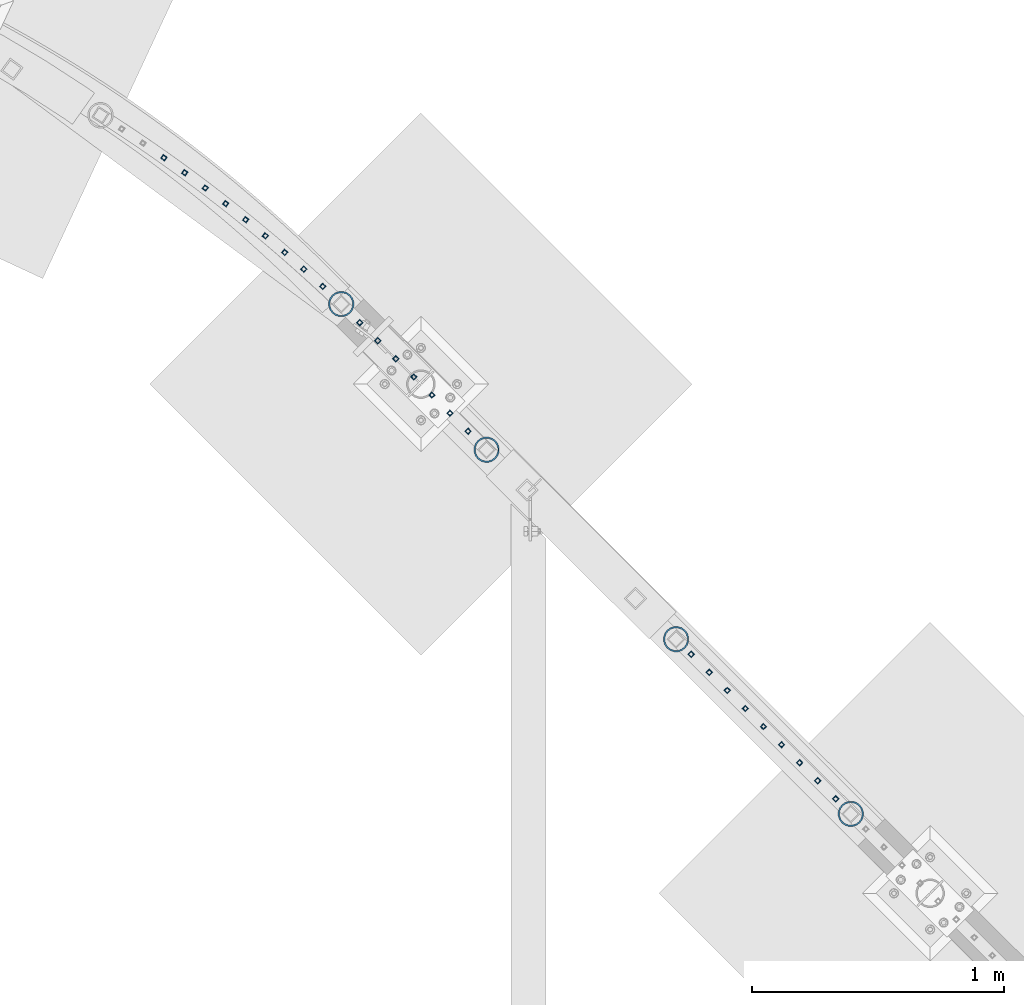
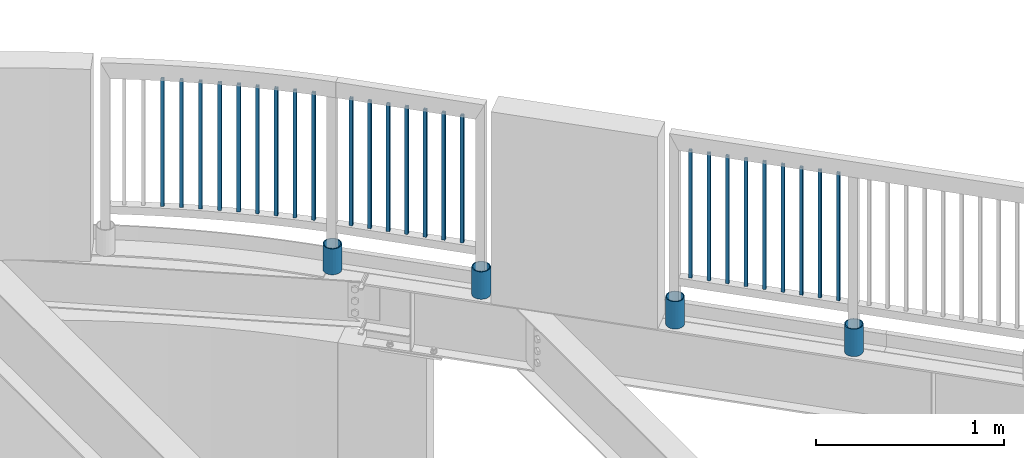
# One storey, part 252 of 975: 29 columns.
"""IFC2X3 building model written with IfcOpenShell, lengths in millimetres."""

import ifcopenshell
import ifcopenshell.guid

model = None  # the IFC model being written
_history = None  # IfcOwnerHistory: only IFC2X3 demands one
_inside = {}  # id of a spatial element -> (the spatial element, [elements in it])
_under = {}  # id of a project, library or spatial element -> (it, [spatial elements below it])
_declared = {}  # id of a project -> (the project, [libraries it declares])
_typed = {}  # id of a type object -> (the type object, [elements of that type])
_made_of = {}  # id of a material, layer set ... -> (it, [elements and type objects made of it])


def new_model(schema):
    """Start an empty IFC model of exactly this schema.

    Asked for "IFC4X3", IfcOpenShell would pick the latest addendum, in which some entities
    have other attributes; the version numbers below select the first issue.
    IFC2X3 requires an IfcOwnerHistory on every rooted entity: one is made here for all.
    """
    global model, _history
    if schema == "IFC4X3":
        model = ifcopenshell.file(schema_version=(4, 3, 0, 0))
    else:
        model = ifcopenshell.file(schema=schema)
    _inside.clear()
    _under.clear()
    _declared.clear()
    _typed.clear()
    _made_of.clear()
    _history = None
    if model.schema == "IFC2X3":
        org = make("IfcOrganization", Name="unknown")
        user = make(
            "IfcPersonAndOrganization",
            ThePerson=make("IfcPerson", FamilyName="unknown"),
            TheOrganization=org,
        )
        app = make(
            "IfcApplication",
            ApplicationDeveloper=org,
            Version="unknown",
            ApplicationFullName="unknown",
            ApplicationIdentifier="unknown",
        )
        _history = make(
            "IfcOwnerHistory",
            OwningUser=user,
            OwningApplication=app,
            ChangeAction="ADDED",
            CreationDate=0,
        )
    return model


def make(cls, **values):
    """One entity of the class cls with the attributes given. An attribute that is None is left unset."""
    return model.create_entity(
        cls, **{name: value for name, value in values.items() if value is not None}
    )


def rooted(cls, **values):
    """An entity with a GlobalId (a new one), such as an element, a storey or a relation."""
    return make(cls, GlobalId=ifcopenshell.guid.new(), OwnerHistory=_history, **values)


def si_unit(unit_type, name, prefix=None):
    """IfcSIUnit, for example si_unit("LENGTHUNIT", "METRE", prefix="MILLI")."""
    return make("IfcSIUnit", UnitType=unit_type, Prefix=prefix, Name=name)


def assignment(units):
    """IfcUnitAssignment: the units of a project."""
    return None if units is None else make("IfcUnitAssignment", Units=units)


def point(xyz):
    """IfcCartesianPoint."""
    return None if xyz is None else make("IfcCartesianPoint", Coordinates=xyz)


def direction(xyz):
    """IfcDirection."""
    return None if xyz is None else make("IfcDirection", DirectionRatios=xyz)


def frame(location, z_axis=None, x_axis=None):
    """IfcAxis2Placement3D, a coordinate frame: its origin and axes. An axis left out is left unset."""
    return make(
        "IfcAxis2Placement3D",
        Location=point(location),
        Axis=direction(z_axis),
        RefDirection=direction(x_axis),
    )


def origin_with_axes():
    """The frame at (0, 0, 0) with the z axis (0, 0, 1) and the x axis (1, 0, 0) written out."""
    return frame((0.0, 0.0, 0.0), z_axis=(0.0, 0.0, 1.0), x_axis=(1.0, 0.0, 0.0))


def place(relative_to, where):
    """IfcLocalPlacement: puts the frame where relative to a parent placement (None: the world)."""
    return make(
        "IfcLocalPlacement", PlacementRelTo=relative_to, RelativePlacement=where
    )


def context(
    kind, dimensions, precision=None, world=None, true_north=None, identifier=None
):
    """IfcGeometricRepresentationContext, for example the 3D "Model" context."""
    return make(
        "IfcGeometricRepresentationContext",
        ContextIdentifier=identifier,
        ContextType=kind,
        CoordinateSpaceDimension=dimensions,
        Precision=precision,
        WorldCoordinateSystem=world,
        TrueNorth=true_north,
    )


def subcontext(parent, identifier, kind, view, scale=None):
    """IfcGeometricRepresentationSubContext, for example "Body" below "Model"."""
    return make(
        "IfcGeometricRepresentationSubContext",
        ContextIdentifier=identifier,
        ContextType=kind,
        ParentContext=parent,
        TargetScale=scale,
        TargetView=view,
    )


def project(units=None, contexts=None):
    """IfcProject with its units and contexts."""
    return rooted(
        "IfcProject",
        Name="project",
        RepresentationContexts=contexts,
        UnitsInContext=assignment(units),
    )


def spatial(cls, under=None, at=None, **own):
    """A site, building, storey or space (cls), placed at a placement, below another one or the project."""
    s = rooted(cls, ObjectPlacement=at, **own)
    if under is not None:
        _under.setdefault(under.id(), (under, []))[1].append(s)
    return s


def faces_of(points, faces, orient=None, outer=None):
    """IfcFace entities. A face is a list of loops; a loop is a list of indices into points, from 0.

    orient and outer hold one flag for each loop. By default every Orientation is true, the
    first loop of a face is its IfcFaceOuterBound and the others are IfcFaceBound.
    """
    made = []
    for i, loops in enumerate(faces):
        bounds = []
        for j, loop in enumerate(loops):
            is_outer = j == 0 if outer is None else outer[i][j]
            bounds.append(
                make(
                    "IfcFaceOuterBound" if is_outer else "IfcFaceBound",
                    Bound=make("IfcPolyLoop", Polygon=[points[k] for k in loop]),
                    Orientation=True if orient is None else orient[i][j],
                )
            )
        made.append(make("IfcFace", Bounds=bounds))
    return made


def faceted_brep(points, faces, orient=None, outer=None, voids=None):
    """IfcFacetedBrep: a solid bounded by flat faces; with voids (closed shells), ...WithVoids."""
    shared = [point(p) for p in points]
    hull = make("IfcClosedShell", CfsFaces=faces_of(shared, faces, orient, outer))
    if voids is None:
        return make("IfcFacetedBrep", Outer=hull)
    return make(
        "IfcFacetedBrepWithVoids",
        Outer=hull,
        Voids=[
            make(cls, CfsFaces=faces_of(shared, fs, o, b)) for cls, fs, o, b in voids
        ],
    )


def shape(context_of_items, identifier, shape_type, items):
    """IfcShapeRepresentation: the items that make up one representation, for example the "Body"."""
    return make(
        "IfcShapeRepresentation",
        ContextOfItems=context_of_items,
        RepresentationIdentifier=identifier,
        RepresentationType=shape_type,
        Items=items,
    )


def material(Name=None, Category=None):
    """IfcMaterial."""
    return make("IfcMaterial", Name=Name, Category=Category)


def made_of(thing, what):
    """Note that an element or type object is made of a material, layer set ...; save() writes the relation."""
    if what is not None:
        _made_of.setdefault(what.id(), (what, []))[1].append(thing)
    return thing


def type_object(cls, material=None, **own):
    """A type object (cls), such as IfcWallType, which elements share."""
    return made_of(rooted(cls, **own), material)


def element(
    cls,
    number,
    at=None,
    inside=None,
    cuts=None,
    type_object=None,
    material=None,
    context=None,
    identifier="Body",
    shape_type=None,
    held_by="IfcProductDefinitionShape",
    body=None,
    shapes=None,
    **own,
):
    """One element of the class cls, such as IfcWall. Its Tag is "e" and its number.

    at: its placement. inside: the storey or other place that contains it. cuts: it is an
    opening in that element (IfcRelVoidsElement). A single representation is given by context,
    identifier, shape_type and body (its items); several are given by shapes. held_by: the class
    of the entity that holds the representations. save() writes the other relations.
    """
    e = rooted(cls, Tag="e%d" % number, ObjectPlacement=at, **own)
    if body is not None:
        shapes = [shape(context, identifier, shape_type, body)]
    if shapes is not None:
        e.Representation = make(held_by, Representations=shapes)
    if inside is not None:
        _inside.setdefault(inside.id(), (inside, []))[1].append(e)
    if cuts is not None:
        rooted(
            "IfcRelVoidsElement", RelatingBuildingElement=cuts, RelatedOpeningElement=e
        )
    if type_object is not None:
        _typed.setdefault(type_object.id(), (type_object, []))[1].append(e)
    return made_of(e, material)


def aggregate(whole, parts):
    """IfcRelAggregates: a whole, such as a stair, and the parts it consists of."""
    return rooted("IfcRelAggregates", RelatingObject=whole, RelatedObjects=parts)


def save(model, path):
    """Write the relations noted so far, then the file.

    IfcRelAggregates (storeys below a building ...), IfcRelContainedInSpatialStructure (elements
    in a storey), IfcRelDefinesByType, IfcRelAssociatesMaterial and IfcRelDeclares: one each for
    every whole, place, type object, material and project.
    """
    for whole, parts in _under.values():
        aggregate(whole, parts)
    for where, things in _inside.values():
        rooted(
            "IfcRelContainedInSpatialStructure",
            RelatedElements=things,
            RelatingStructure=where,
        )
    for kind, things in _typed.values():
        rooted("IfcRelDefinesByType", RelatedObjects=things, RelatingType=kind)
    for what, things in _made_of.values():
        rooted("IfcRelAssociatesMaterial", RelatedObjects=things, RelatingMaterial=what)
    for by, libraries in _declared.values():
        rooted("IfcRelDeclares", RelatingContext=by, RelatedDefinitions=libraries)
    model.write(path)


model = new_model("IFC2X3")

# Units and contexts
model_context = context("Model", 3, precision=1e-05, world=origin_with_axes())
body_context = subcontext(model_context, "Body", "Model", "MODEL_VIEW")
ifc_project = project(units=[si_unit("LENGTHUNIT", "METRE", prefix="MILLI"), si_unit("AREAUNIT", "SQUARE_METRE"), si_unit("VOLUMEUNIT", "CUBIC_METRE"), si_unit("MASSUNIT", "GRAM", prefix="KILO"), si_unit("TIMEUNIT", "SECOND"), si_unit("PLANEANGLEUNIT", "RADIAN"), si_unit("SOLIDANGLEUNIT", "STERADIAN"), si_unit("THERMODYNAMICTEMPERATUREUNIT", "DEGREE_CELSIUS"), si_unit("LUMINOUSINTENSITYUNIT", "LUMEN")], contexts=[model_context])

# Site, building, storey
site_placement = place(None, origin_with_axes())
site = spatial("IfcSite", under=ifc_project, at=site_placement, CompositionType="ELEMENT")
building_placement = place(site_placement, origin_with_axes())
building = spatial("IfcBuilding", under=site, at=building_placement, Name="Undefined", CompositionType="ELEMENT")
storey_placement = place(building_placement, origin_with_axes())
storey = spatial("IfcBuildingStorey", under=building, at=storey_placement, Name="Undefined", CompositionType="ELEMENT", Elevation=0.0)

# Columns
ifc_material_1 = material()
column_type_1 = type_object("IfcColumnType", Name="HSS3/4X3/4X.120_TUBES", PredefinedType="NOTDEFINED")
for number, where, z_axis, x_axis, name in (
    (1, (20918.4968090525, 27716.0820538778, 4254.50002056753), (0.707106781186548, 0.707106781186548, 0.0), (0.0, 0.0, 1.0), "PICKET"),
    (2, (20846.7551458588, 27788.0244886211, 4254.50002056753), (0.707106781186548, 0.707106781186548, 0.0), (0.0, 0.0, 1.0), "PICKET"),
    (3, (20775.0134826651, 27859.9669233644, 4254.50002056753), (0.708094138880933, 0.706118042881266, -1.34340261865873e-08), (0.0, 0.0, 1.0), "PICKET"),
    (4, (20703.287272293, 27931.8938620408, 4254.50002056753), (0.708094138880933, 0.706118042881266, -1.34340261865873e-08), (0.0, 0.0, 1.0), "PICKET"),
    (5, (20631.5301562776, 28003.851792851, 4254.50002056753), (0.707106781186548, 0.707106781186548, 0.0), (0.0, 0.0, 1.0), "PICKET"),
    (6, (20559.7851544616, 28075.7975755598, 4254.50002056753), (0.708094138880933, 0.706118042881266, -1.34340261865873e-08), (0.0, 0.0, 1.0), "PICKET"),
    (7, (20488.1542263098, 28147.8440587572, 4254.50002056753), (0.706264336941061, 0.707948222940918, -1.3435859727906e-08), (0.0, 0.0, 1.0), "PICKET"),
    (8, (20189.6564368227, 28427.2775101211, 4254.50002056753), (0.658049943617107, 0.752974283561877, -1.42051667353371e-08), (0.0, 0.0, 1.0), "PICKET"),
    (9, (20265.6748191918, 28360.2261086125, 4254.50002056753), (0.670843874445818, 0.741598608492845, -1.34535794131807e-08), (0.0, 0.0, 1.0), "PICKET"),
    (10, (20340.8530768504, 28291.7565442089, 4254.50002056753), (0.680333506985498, 0.732902666984377, -1.34520269057248e-08), (0.0, 0.0, 1.0), "PICKET"),
    (11, (20112.5823071785, 28492.711185891, 4254.50002056753), (0.644394403952403, 0.764693305943518, -1.42111757668317e-08), (0.0, 0.0, 1.0), "PICKET"),
    (12, (20034.7560553792, 28556.8524414697, 4254.50002056753), (0.630530202951471, 0.776164713940267, -1.42125836646301e-08), (0.0, 0.0, 1.0), "PICKET"),
    (13, (19954.8768536325, 28620.6520689143, 4254.50002056753), (0.616461829970842, 0.787384792962755, -1.35929294629022e-08), (0.0, 0.0, 1.0), "PICKET"),
    (14, (19874.0534367623, 28682.9553399649, 4254.50002056753), (0.602193841836496, 0.798349908783236, -1.35994014272001e-08), (0.0, 0.0, 1.0), "PICKET"),
    (15, (19792.2485653983, 28743.6994028625, 4254.50002056753), (0.592573231122728, 0.805516583166833, -1.36012695293175e-08), (0.0, 0.0, 1.0), "PICKET"),
    (16, (19709.6410499453, 28803.1475329362, 4254.50002056753), (0.577982847047769, 0.816048913067443, -1.36004027808667e-08), (0.0, 0.0, 1.0), "PICKET"),
    (17, (21805.3704688618, 26829.5236108806, 4254.49977857385), (-0.707106781186601, 0.707106781186494, 2.36468622460961e-14), (0.0, 0.0, 1.0), "PICKET"),
    (18, (21877.2048438618, 26757.6892358806, 4254.49977857385), (-0.707106781186601, 0.707106781186494, 2.36468622460961e-14), (0.0, 0.0, 1.0), "PICKET"),
    (19, (21949.0392188618, 26685.8548608806, 4254.49977857385), (-0.707106781186601, 0.707106781186494, 2.36468622460961e-14), (0.0, 0.0, 1.0), "PICKET"),
    (20, (22020.8735938618, 26614.0204858806, 4254.49977857385), (-0.707106781186601, 0.707106781186494, 2.36468622460961e-14), (0.0, 0.0, 1.0), "PICKET"),
    (21, (22092.7079688618, 26542.1861108806, 4254.49977857385), (-0.707106781186601, 0.707106781186494, 2.36468622460961e-14), (0.0, 0.0, 1.0), "PICKET"),
    (22, (22164.5423438618, 26470.3517358806, 4254.49977857385), (-0.707106781186601, 0.707106781186494, 2.36468622460961e-14), (0.0, 0.0, 1.0), "PICKET"),
    (23, (22236.3767188618, 26398.5173608806, 4254.49977857385), (-0.707106781186601, 0.707106781186494, 2.36468622460961e-14), (0.0, 0.0, 1.0), "PICKET"),
    (24, (22308.2110938618, 26326.6829858806, 4254.49977857385), (-0.707106781186601, 0.707106781186494, 2.36468622460961e-14), (0.0, 0.0, 1.0), "PICKET"),
    (25, (22380.0454688618, 26254.8486108806, 4254.49977857385), (-0.707106781186601, 0.707106781186494, 2.36468622460961e-14), (0.0, 0.0, 1.0), "PICKET"),
):
    element("IfcColumn", number, at=place(storey_placement, frame(where, z_axis=z_axis, x_axis=x_axis)), inside=storey, type_object=column_type_1, material=ifc_material_1, Name=name, ObjectType="HSS3/4X3/4X.120_TUBES", context=body_context, shape_type="Brep", body=[
        faceted_brep([(0.0, 6.34999999998763, -6.34999999998763), (0.0, -6.35000000000582, -6.34999999998763), (825.49997943247, -6.35000000000582, -6.34999999998763), (825.49997943247, 6.34999999998763, -6.34999999998763), (0.0, -6.34999999998763, 6.34999999998763), (825.49997943247, -6.34999999998763, 6.34999999998763), (0.0, 6.35000000000946, 6.34999999998763), (825.49997943247, 6.35000000000946, 6.34999999998763), (0.0, 9.52499999997963, -9.52499999997963), (0.0, 9.52500000000873, 9.5249999999869), (825.49997943247, 9.52500000000873, 9.5249999999869), (825.49997943247, 9.52499999997963, -9.52499999997963), (0.0, -9.52499999997963, 9.52499999998327), (825.49997943247, -9.52499999997963, 9.52499999998327), (0.0, -9.52500000000873, -9.5249999999869), (825.49997943247, -9.52500000000873, -9.5249999999869)], [[[0, 1, 2, 3]], [[1, 4, 5, 2]], [[4, 6, 7, 5]], [[6, 0, 3, 7]], [[8, 9, 10, 11]], [[9, 12, 13, 10]], [[12, 14, 15, 13]], [[14, 8, 11, 15]], [[13, 15, 11, 10], [5, 7, 3, 2]], [[14, 12, 9, 8], [6, 4, 1, 0]]]),
    ])
ifc_material_2 = material(Name="STEEL/A53")
column_type_2 = type_object("IfcColumnType", Name="PIPE3-1/2STD", PredefinedType="NOTDEFINED")
column_1_placement = place(storey_placement, frame((20414.5992550041, 28221.6349313363, 3946.525), z_axis=(-0.707106781186601, 0.707106781186494, 2.36468622460961e-14), x_axis=(0.0, 0.0, 1.0)))
element("IfcColumn", 26, at=column_1_placement, inside=storey, type_object=column_type_2, material=ifc_material_2, ObjectType="PIPE3-1/2STD", context=body_context, shape_type="Brep", body=[
    faceted_brep([(0.0, -45.0595999999932, 1.45519152283669e-11), (0.0, -42.8542262016344, 13.924182159768), (168.275, -42.8542262015544, 13.9241821597034), (168.275, -45.0595999998914, 2.72848410531878e-12), (0.0, -36.45398215971, 26.4853683542424), (168.275, -36.4539821596554, 26.485368354136), (0.0, -26.4853683541623, 36.45398215979), (168.275, -26.4853683541369, 36.4539821596509), (0.0, -13.9241821596988, 42.8542262017108), (168.275, -13.9241821597025, 42.8542262015517), (0.0, 3.63797880709171e-11, 45.0596000000514), (168.275, 0.0, 45.0595999998905), (0.0, 13.9241821597716, 42.8542262017036), (168.275, 13.9241821597025, 42.8542262015517), (0.0, 26.4853683542242, 36.4539821597718), (168.275, 26.4853683541296, 36.4539821596509), (0.0, 36.4539821597537, 26.4853683542206), (168.275, 36.4539821596481, 26.4853683541342), (0.0, 42.8542262016563, 13.9241821597425), (168.275, 42.8542262015471, 13.9241821597034), (0.0, 45.0595999999932, -1.09139364212751e-11), (168.275, 45.0595999998914, -9.09494701772928e-13), (0.0, 42.8542262016344, -13.9241821597643), (168.275, 42.8542262015471, -13.9241821596997), (0.0, 36.45398215971, -26.4853683542387), (168.275, 36.4539821596481, -26.4853683541323), (0.0, 26.4853683541623, -36.4539821597864), (168.275, 26.4853683541296, -36.4539821596472), (0.0, 13.9241821596988, -42.8542262017072), (168.275, 13.9241821596952, -42.854226201548), (0.0, -3.63797880709171e-11, -45.0596000000478), (168.275, 0.0, -45.0595999998886), (0.0, -13.9241821597716, -42.8542262016963), (168.275, -13.9241821597025, -42.8542262015499), (0.0, -26.4853683542242, -36.4539821597682), (168.275, -26.4853683541369, -36.4539821596472), (0.0, -36.4539821597537, -26.4853683542169), (168.275, -36.4539821596554, -26.4853683541305), (0.0, -42.8542262016563, -13.9241821597352), (168.275, -42.8542262015544, -13.9241821597016), (0.0, -50.799999999992, 1.81898940354586e-11), (0.0, -48.3136710278013, -15.6980633142484), (168.275, -48.3136710276813, -15.6980633142075), (168.275, -50.7999999998792, 9.09494701772928e-13), (0.0, -41.0980633142644, -29.8594908164741), (168.275, -41.0980633141517, -29.8594908163841), (0.0, -29.859490816485, -41.0980633142826), (168.275, -29.8594908163868, -41.0980633141471), (0.0, -15.6980633142848, -48.313671027845), (168.275, -15.6980633142084, -48.3136710276767), (0.0, -4.36557456851006e-11, -50.8000000000575), (168.275, 0.0, -50.7999999998747), (0.0, 15.6980633142011, -48.3136710278523), (168.275, 15.6980633142084, -48.3136710276749), (0.0, 29.8594908164159, -41.0980633143045), (168.275, 29.8594908163868, -41.0980633141471), (0.0, 41.0980633142135, -29.8594908165032), (168.275, 41.0980633141444, -29.8594908163859), (0.0, 48.3136710277722, -15.6980633142775), (168.275, 48.313671027674, -15.6980633142057), (0.0, 50.799999999992, -1.45519152283669e-11), (168.275, 50.7999999998719, 9.09494701772928e-13), (0.0, 48.313671027794, 15.6980633142521), (168.275, 48.313671027674, 15.6980633142093), (0.0, 41.0980633142644, 29.8594908164814), (168.275, 41.0980633141444, 29.8594908163877), (0.0, 29.859490816485, 41.0980633142863), (168.275, 29.8594908163795, 41.0980633141507), (0.0, 15.6980633142848, 48.3136710278486), (168.275, 15.6980633142084, 48.3136710276785), (0.0, 4.00177668780088e-11, 50.8000000000611), (168.275, 0.0, 50.7999999998765), (0.0, -15.6980633142011, 48.3136710278559), (168.275, -15.6980633142084, 48.3136710276785), (0.0, -29.8594908164159, 41.0980633143081), (168.275, -29.8594908163941, 41.0980633141507), (0.0, -41.0980633142171, 29.8594908165069), (168.275, -41.0980633141517, 29.8594908163896), (0.0, -48.3136710277722, 15.6980633142812), (168.275, -48.3136710276813, 15.6980633142093)], [[[0, 1, 2, 3]], [[1, 4, 5, 2]], [[4, 6, 7, 5]], [[6, 8, 9, 7]], [[8, 10, 11, 9]], [[10, 12, 13, 11]], [[12, 14, 15, 13]], [[14, 16, 17, 15]], [[16, 18, 19, 17]], [[18, 20, 21, 19]], [[20, 22, 23, 21]], [[22, 24, 25, 23]], [[24, 26, 27, 25]], [[26, 28, 29, 27]], [[28, 30, 31, 29]], [[30, 32, 33, 31]], [[32, 34, 35, 33]], [[34, 36, 37, 35]], [[36, 38, 39, 37]], [[38, 0, 3, 39]], [[40, 41, 42, 43]], [[41, 44, 45, 42]], [[44, 46, 47, 45]], [[46, 48, 49, 47]], [[48, 50, 51, 49]], [[50, 52, 53, 51]], [[52, 54, 55, 53]], [[54, 56, 57, 55]], [[56, 58, 59, 57]], [[58, 60, 61, 59]], [[60, 62, 63, 61]], [[62, 64, 65, 63]], [[64, 66, 67, 65]], [[66, 68, 69, 67]], [[68, 70, 71, 69]], [[70, 72, 73, 71]], [[72, 74, 75, 73]], [[74, 76, 77, 75]], [[76, 78, 79, 77]], [[78, 40, 43, 79]], [[45, 47, 49, 51, 53, 55, 57, 59, 61, 63, 65, 67, 69, 71, 73, 75, 77, 79, 43, 42], [5, 7, 9, 11, 13, 15, 17, 19, 21, 23, 25, 27, 29, 31, 33, 35, 37, 39, 3, 2]], [[78, 76, 74, 72, 70, 68, 66, 64, 62, 60, 58, 56, 54, 52, 50, 48, 46, 44, 41, 40], [38, 36, 34, 32, 30, 28, 26, 24, 22, 20, 18, 16, 14, 12, 10, 8, 6, 4, 1, 0]]]),
])
column_2_placement = place(storey_placement, frame((22439.9387856741, 26195.1043298841, 3937.0), z_axis=(-0.707106781186601, 0.707106781186494, 2.36468622460961e-14), x_axis=(0.0, 0.0, 1.0)))
element("IfcColumn", 27, at=column_2_placement, inside=storey, type_object=column_type_2, material=ifc_material_2, ObjectType="PIPE3-1/2STD", context=body_context, shape_type="Brep", body=[
    faceted_brep([(0.0, -45.0595999999932, 1.45519152283669e-11), (0.0, -42.8542262016344, 13.924182159768), (177.8, -42.8542262016344, 13.924182159768), (177.8, -45.0595999999932, 1.45519152283669e-11), (0.0, -36.45398215971, 26.4853683542424), (177.8, -36.45398215971, 26.4853683542424), (0.0, -26.4853683541623, 36.45398215979), (177.8, -26.4853683541623, 36.45398215979), (0.0, -13.9241821596988, 42.8542262017108), (177.8, -13.9241821596988, 42.8542262017108), (0.0, 3.63797880709171e-11, 45.0596000000514), (177.8, 3.63797880709171e-11, 45.0596000000514), (0.0, 13.9241821597716, 42.8542262017036), (177.8, 13.9241821597716, 42.8542262017036), (0.0, 26.4853683542242, 36.4539821597718), (177.8, 26.4853683542242, 36.4539821597718), (0.0, 36.4539821597537, 26.4853683542206), (177.8, 36.4539821597537, 26.4853683542206), (0.0, 42.8542262016563, 13.9241821597425), (177.8, 42.8542262016563, 13.9241821597425), (0.0, 45.0595999999932, -1.09139364212751e-11), (177.8, 45.0595999999932, -1.09139364212751e-11), (0.0, 42.8542262016344, -13.9241821597643), (177.8, 42.8542262016344, -13.9241821597643), (0.0, 36.45398215971, -26.4853683542387), (177.8, 36.45398215971, -26.4853683542387), (0.0, 26.4853683541623, -36.4539821597864), (177.8, 26.4853683541623, -36.4539821597864), (0.0, 13.9241821596988, -42.8542262017072), (177.8, 13.9241821596988, -42.8542262017072), (0.0, -3.63797880709171e-11, -45.0596000000478), (177.8, -3.63797880709171e-11, -45.0596000000478), (0.0, -13.9241821597716, -42.8542262016963), (177.8, -13.9241821597716, -42.8542262016963), (0.0, -26.4853683542242, -36.4539821597682), (177.8, -26.4853683542242, -36.4539821597682), (0.0, -36.4539821597537, -26.4853683542169), (177.8, -36.4539821597537, -26.4853683542169), (0.0, -42.8542262016563, -13.9241821597352), (177.8, -42.8542262016563, -13.9241821597352), (0.0, -50.799999999992, 1.81898940354586e-11), (0.0, -48.3136710278013, -15.6980633142484), (177.8, -48.3136710278013, -15.6980633142484), (177.8, -50.799999999992, 1.81898940354586e-11), (0.0, -41.0980633142644, -29.8594908164741), (177.8, -41.0980633142644, -29.8594908164741), (0.0, -29.859490816485, -41.0980633142826), (177.8, -29.859490816485, -41.0980633142826), (0.0, -15.6980633142848, -48.313671027845), (177.8, -15.6980633142848, -48.313671027845), (0.0, -4.36557456851006e-11, -50.8000000000575), (177.8, -4.36557456851006e-11, -50.8000000000575), (0.0, 15.6980633142011, -48.3136710278523), (177.8, 15.6980633142011, -48.3136710278523), (0.0, 29.8594908164159, -41.0980633143045), (177.8, 29.8594908164159, -41.0980633143045), (0.0, 41.0980633142135, -29.8594908165032), (177.8, 41.0980633142135, -29.8594908165032), (0.0, 48.3136710277722, -15.6980633142775), (177.8, 48.3136710277722, -15.6980633142775), (0.0, 50.799999999992, -1.45519152283669e-11), (177.8, 50.799999999992, -1.45519152283669e-11), (0.0, 48.313671027794, 15.6980633142521), (177.8, 48.313671027794, 15.6980633142521), (0.0, 41.0980633142644, 29.8594908164814), (177.8, 41.0980633142644, 29.8594908164814), (0.0, 29.859490816485, 41.0980633142863), (177.8, 29.859490816485, 41.0980633142863), (0.0, 15.6980633142848, 48.3136710278486), (177.8, 15.6980633142848, 48.3136710278486), (0.0, 4.00177668780088e-11, 50.8000000000611), (177.8, 4.00177668780088e-11, 50.8000000000611), (0.0, -15.6980633142011, 48.3136710278559), (177.8, -15.6980633142011, 48.3136710278559), (0.0, -29.8594908164159, 41.0980633143081), (177.8, -29.8594908164159, 41.0980633143081), (0.0, -41.0980633142171, 29.8594908165069), (177.8, -41.0980633142171, 29.8594908165069), (0.0, -48.3136710277722, 15.6980633142812), (177.8, -48.3136710277722, 15.6980633142812)], [[[0, 1, 2, 3]], [[1, 4, 5, 2]], [[4, 6, 7, 5]], [[6, 8, 9, 7]], [[8, 10, 11, 9]], [[10, 12, 13, 11]], [[12, 14, 15, 13]], [[14, 16, 17, 15]], [[16, 18, 19, 17]], [[18, 20, 21, 19]], [[20, 22, 23, 21]], [[22, 24, 25, 23]], [[24, 26, 27, 25]], [[26, 28, 29, 27]], [[28, 30, 31, 29]], [[30, 32, 33, 31]], [[32, 34, 35, 33]], [[34, 36, 37, 35]], [[36, 38, 39, 37]], [[38, 0, 3, 39]], [[40, 41, 42, 43]], [[41, 44, 45, 42]], [[44, 46, 47, 45]], [[46, 48, 49, 47]], [[48, 50, 51, 49]], [[50, 52, 53, 51]], [[52, 54, 55, 53]], [[54, 56, 57, 55]], [[56, 58, 59, 57]], [[58, 60, 61, 59]], [[60, 62, 63, 61]], [[62, 64, 65, 63]], [[64, 66, 67, 65]], [[66, 68, 69, 67]], [[68, 70, 71, 69]], [[70, 72, 73, 71]], [[72, 74, 75, 73]], [[74, 76, 77, 75]], [[76, 78, 79, 77]], [[78, 40, 43, 79]], [[45, 47, 49, 51, 53, 55, 57, 59, 61, 63, 65, 67, 69, 71, 73, 75, 77, 79, 43, 42], [5, 7, 9, 11, 13, 15, 17, 19, 21, 23, 25, 27, 29, 31, 33, 35, 37, 39, 3, 2]], [[78, 76, 74, 72, 70, 68, 66, 64, 62, 60, 58, 56, 54, 52, 50, 48, 46, 44, 41, 40], [38, 36, 34, 32, 30, 28, 26, 24, 22, 20, 18, 16, 14, 12, 10, 8, 6, 4, 1, 0]]]),
])
column_3_placement = place(storey_placement, frame((20992.190744755, 27642.644923468, 3937.0), z_axis=(-0.707106781186601, 0.707106781186494, 2.36468622460961e-14), x_axis=(0.0, 0.0, 1.0)))
element("IfcColumn", 28, at=column_3_placement, inside=storey, type_object=column_type_2, material=ifc_material_2, ObjectType="PIPE3-1/2STD", context=body_context, shape_type="Brep", body=[
    faceted_brep([(0.0, -45.0595999999932, 1.45519152283669e-11), (0.0, -42.8542262016344, 13.924182159768), (177.8, -42.8542262016344, 13.924182159768), (177.8, -45.0595999999932, 1.45519152283669e-11), (0.0, -36.45398215971, 26.4853683542424), (177.8, -36.45398215971, 26.4853683542424), (0.0, -26.4853683541623, 36.45398215979), (177.8, -26.4853683541623, 36.45398215979), (0.0, -13.9241821596988, 42.8542262017108), (177.8, -13.9241821596988, 42.8542262017108), (0.0, 3.63797880709171e-11, 45.0596000000514), (177.8, 3.63797880709171e-11, 45.0596000000514), (0.0, 13.9241821597716, 42.8542262017036), (177.8, 13.9241821597716, 42.8542262017036), (0.0, 26.4853683542242, 36.4539821597718), (177.8, 26.4853683542242, 36.4539821597718), (0.0, 36.4539821597537, 26.4853683542206), (177.8, 36.4539821597537, 26.4853683542206), (0.0, 42.8542262016563, 13.9241821597425), (177.8, 42.8542262016563, 13.9241821597425), (0.0, 45.0595999999932, -1.09139364212751e-11), (177.8, 45.0595999999932, -1.09139364212751e-11), (0.0, 42.8542262016344, -13.9241821597643), (177.8, 42.8542262016344, -13.9241821597643), (0.0, 36.45398215971, -26.4853683542387), (177.8, 36.45398215971, -26.4853683542387), (0.0, 26.4853683541623, -36.4539821597864), (177.8, 26.4853683541623, -36.4539821597864), (0.0, 13.9241821596988, -42.8542262017072), (177.8, 13.9241821596988, -42.8542262017072), (0.0, -3.63797880709171e-11, -45.0596000000478), (177.8, -3.63797880709171e-11, -45.0596000000478), (0.0, -13.9241821597716, -42.8542262016963), (177.8, -13.9241821597716, -42.8542262016963), (0.0, -26.4853683542242, -36.4539821597682), (177.8, -26.4853683542242, -36.4539821597682), (0.0, -36.4539821597537, -26.4853683542169), (177.8, -36.4539821597537, -26.4853683542169), (0.0, -42.8542262016563, -13.9241821597352), (177.8, -42.8542262016563, -13.9241821597352), (0.0, -50.799999999992, 1.81898940354586e-11), (0.0, -48.3136710278013, -15.6980633142484), (177.8, -48.3136710278013, -15.6980633142484), (177.8, -50.799999999992, 1.81898940354586e-11), (0.0, -41.0980633142644, -29.8594908164741), (177.8, -41.0980633142644, -29.8594908164741), (0.0, -29.859490816485, -41.0980633142826), (177.8, -29.859490816485, -41.0980633142826), (0.0, -15.6980633142848, -48.313671027845), (177.8, -15.6980633142848, -48.313671027845), (0.0, -4.36557456851006e-11, -50.8000000000575), (177.8, -4.36557456851006e-11, -50.8000000000575), (0.0, 15.6980633142011, -48.3136710278523), (177.8, 15.6980633142011, -48.3136710278523), (0.0, 29.8594908164159, -41.0980633143045), (177.8, 29.8594908164159, -41.0980633143045), (0.0, 41.0980633142135, -29.8594908165032), (177.8, 41.0980633142135, -29.8594908165032), (0.0, 48.3136710277722, -15.6980633142775), (177.8, 48.3136710277722, -15.6980633142775), (0.0, 50.799999999992, -1.45519152283669e-11), (177.8, 50.799999999992, -1.45519152283669e-11), (0.0, 48.313671027794, 15.6980633142521), (177.8, 48.313671027794, 15.6980633142521), (0.0, 41.0980633142644, 29.8594908164814), (177.8, 41.0980633142644, 29.8594908164814), (0.0, 29.859490816485, 41.0980633142863), (177.8, 29.859490816485, 41.0980633142863), (0.0, 15.6980633142848, 48.3136710278486), (177.8, 15.6980633142848, 48.3136710278486), (0.0, 4.00177668780088e-11, 50.8000000000611), (177.8, 4.00177668780088e-11, 50.8000000000611), (0.0, -15.6980633142011, 48.3136710278559), (177.8, -15.6980633142011, 48.3136710278559), (0.0, -29.8594908164159, 41.0980633143081), (177.8, -29.8594908164159, 41.0980633143081), (0.0, -41.0980633142171, 29.8594908165069), (177.8, -41.0980633142171, 29.8594908165069), (0.0, -48.3136710277722, 15.6980633142812), (177.8, -48.3136710277722, 15.6980633142812)], [[[0, 1, 2, 3]], [[1, 4, 5, 2]], [[4, 6, 7, 5]], [[6, 8, 9, 7]], [[8, 10, 11, 9]], [[10, 12, 13, 11]], [[12, 14, 15, 13]], [[14, 16, 17, 15]], [[16, 18, 19, 17]], [[18, 20, 21, 19]], [[20, 22, 23, 21]], [[22, 24, 25, 23]], [[24, 26, 27, 25]], [[26, 28, 29, 27]], [[28, 30, 31, 29]], [[30, 32, 33, 31]], [[32, 34, 35, 33]], [[34, 36, 37, 35]], [[36, 38, 39, 37]], [[38, 0, 3, 39]], [[40, 41, 42, 43]], [[41, 44, 45, 42]], [[44, 46, 47, 45]], [[46, 48, 49, 47]], [[48, 50, 51, 49]], [[50, 52, 53, 51]], [[52, 54, 55, 53]], [[54, 56, 57, 55]], [[56, 58, 59, 57]], [[58, 60, 61, 59]], [[60, 62, 63, 61]], [[62, 64, 65, 63]], [[64, 66, 67, 65]], [[66, 68, 69, 67]], [[68, 70, 71, 69]], [[70, 72, 73, 71]], [[72, 74, 75, 73]], [[74, 76, 77, 75]], [[76, 78, 79, 77]], [[78, 40, 43, 79]], [[45, 47, 49, 51, 53, 55, 57, 59, 61, 63, 65, 67, 69, 71, 73, 75, 77, 79, 43, 42], [5, 7, 9, 11, 13, 15, 17, 19, 21, 23, 25, 27, 29, 31, 33, 35, 37, 39, 3, 2]], [[78, 76, 74, 72, 70, 68, 66, 64, 62, 60, 58, 56, 54, 52, 50, 48, 46, 44, 41, 40], [38, 36, 34, 32, 30, 28, 26, 24, 22, 20, 18, 16, 14, 12, 10, 8, 6, 4, 1, 0]]]),
])
column_4_placement = place(storey_placement, frame((21745.459494755, 26889.574609468, 3937.0), z_axis=(-0.707106781186601, 0.707106781186494, 2.36468622460961e-14), x_axis=(0.0, 0.0, 1.0)))
element("IfcColumn", 29, at=column_4_placement, inside=storey, type_object=column_type_2, material=ifc_material_2, ObjectType="PIPE3-1/2STD", context=body_context, shape_type="Brep", body=[
    faceted_brep([(0.0, -45.0595999999932, 1.45519152283669e-11), (0.0, -42.8542262016344, 13.924182159768), (177.8, -42.8542262016344, 13.924182159768), (177.8, -45.0595999999932, 1.45519152283669e-11), (0.0, -36.45398215971, 26.4853683542424), (177.8, -36.45398215971, 26.4853683542424), (0.0, -26.4853683541623, 36.45398215979), (177.8, -26.4853683541623, 36.45398215979), (0.0, -13.9241821596988, 42.8542262017108), (177.8, -13.9241821596988, 42.8542262017108), (0.0, 3.63797880709171e-11, 45.0596000000514), (177.8, 3.63797880709171e-11, 45.0596000000514), (0.0, 13.9241821597716, 42.8542262017036), (177.8, 13.9241821597716, 42.8542262017036), (0.0, 26.4853683542242, 36.4539821597718), (177.8, 26.4853683542242, 36.4539821597718), (0.0, 36.4539821597537, 26.4853683542206), (177.8, 36.4539821597537, 26.4853683542206), (0.0, 42.8542262016563, 13.9241821597425), (177.8, 42.8542262016563, 13.9241821597425), (0.0, 45.0595999999932, -1.09139364212751e-11), (177.8, 45.0595999999932, -1.09139364212751e-11), (0.0, 42.8542262016344, -13.9241821597643), (177.8, 42.8542262016344, -13.9241821597643), (0.0, 36.45398215971, -26.4853683542387), (177.8, 36.45398215971, -26.4853683542387), (0.0, 26.4853683541623, -36.4539821597864), (177.8, 26.4853683541623, -36.4539821597864), (0.0, 13.9241821596988, -42.8542262017072), (177.8, 13.9241821596988, -42.8542262017072), (0.0, -3.63797880709171e-11, -45.0596000000478), (177.8, -3.63797880709171e-11, -45.0596000000478), (0.0, -13.9241821597716, -42.8542262016963), (177.8, -13.9241821597716, -42.8542262016963), (0.0, -26.4853683542242, -36.4539821597682), (177.8, -26.4853683542242, -36.4539821597682), (0.0, -36.4539821597537, -26.4853683542169), (177.8, -36.4539821597537, -26.4853683542169), (0.0, -42.8542262016563, -13.9241821597352), (177.8, -42.8542262016563, -13.9241821597352), (0.0, -50.799999999992, 1.81898940354586e-11), (0.0, -48.3136710278013, -15.6980633142484), (177.8, -48.3136710278013, -15.6980633142484), (177.8, -50.799999999992, 1.81898940354586e-11), (0.0, -41.0980633142644, -29.8594908164741), (177.8, -41.0980633142644, -29.8594908164741), (0.0, -29.859490816485, -41.0980633142826), (177.8, -29.859490816485, -41.0980633142826), (0.0, -15.6980633142848, -48.313671027845), (177.8, -15.6980633142848, -48.313671027845), (0.0, -4.36557456851006e-11, -50.8000000000575), (177.8, -4.36557456851006e-11, -50.8000000000575), (0.0, 15.6980633142011, -48.3136710278523), (177.8, 15.6980633142011, -48.3136710278523), (0.0, 29.8594908164159, -41.0980633143045), (177.8, 29.8594908164159, -41.0980633143045), (0.0, 41.0980633142135, -29.8594908165032), (177.8, 41.0980633142135, -29.8594908165032), (0.0, 48.3136710277722, -15.6980633142775), (177.8, 48.3136710277722, -15.6980633142775), (0.0, 50.799999999992, -1.45519152283669e-11), (177.8, 50.799999999992, -1.45519152283669e-11), (0.0, 48.313671027794, 15.6980633142521), (177.8, 48.313671027794, 15.6980633142521), (0.0, 41.0980633142644, 29.8594908164814), (177.8, 41.0980633142644, 29.8594908164814), (0.0, 29.859490816485, 41.0980633142863), (177.8, 29.859490816485, 41.0980633142863), (0.0, 15.6980633142848, 48.3136710278486), (177.8, 15.6980633142848, 48.3136710278486), (0.0, 4.00177668780088e-11, 50.8000000000611), (177.8, 4.00177668780088e-11, 50.8000000000611), (0.0, -15.6980633142011, 48.3136710278559), (177.8, -15.6980633142011, 48.3136710278559), (0.0, -29.8594908164159, 41.0980633143081), (177.8, -29.8594908164159, 41.0980633143081), (0.0, -41.0980633142171, 29.8594908165069), (177.8, -41.0980633142171, 29.8594908165069), (0.0, -48.3136710277722, 15.6980633142812), (177.8, -48.3136710277722, 15.6980633142812)], [[[0, 1, 2, 3]], [[1, 4, 5, 2]], [[4, 6, 7, 5]], [[6, 8, 9, 7]], [[8, 10, 11, 9]], [[10, 12, 13, 11]], [[12, 14, 15, 13]], [[14, 16, 17, 15]], [[16, 18, 19, 17]], [[18, 20, 21, 19]], [[20, 22, 23, 21]], [[22, 24, 25, 23]], [[24, 26, 27, 25]], [[26, 28, 29, 27]], [[28, 30, 31, 29]], [[30, 32, 33, 31]], [[32, 34, 35, 33]], [[34, 36, 37, 35]], [[36, 38, 39, 37]], [[38, 0, 3, 39]], [[40, 41, 42, 43]], [[41, 44, 45, 42]], [[44, 46, 47, 45]], [[46, 48, 49, 47]], [[48, 50, 51, 49]], [[50, 52, 53, 51]], [[52, 54, 55, 53]], [[54, 56, 57, 55]], [[56, 58, 59, 57]], [[58, 60, 61, 59]], [[60, 62, 63, 61]], [[62, 64, 65, 63]], [[64, 66, 67, 65]], [[66, 68, 69, 67]], [[68, 70, 71, 69]], [[70, 72, 73, 71]], [[72, 74, 75, 73]], [[74, 76, 77, 75]], [[76, 78, 79, 77]], [[78, 40, 43, 79]], [[45, 47, 49, 51, 53, 55, 57, 59, 61, 63, 65, 67, 69, 71, 73, 75, 77, 79, 43, 42], [5, 7, 9, 11, 13, 15, 17, 19, 21, 23, 25, 27, 29, 31, 33, 35, 37, 39, 3, 2]], [[78, 76, 74, 72, 70, 68, 66, 64, 62, 60, 58, 56, 54, 52, 50, 48, 46, 44, 41, 40], [38, 36, 34, 32, 30, 28, 26, 24, 22, 20, 18, 16, 14, 12, 10, 8, 6, 4, 1, 0]]]),
])

save(model, "model.ifc")
